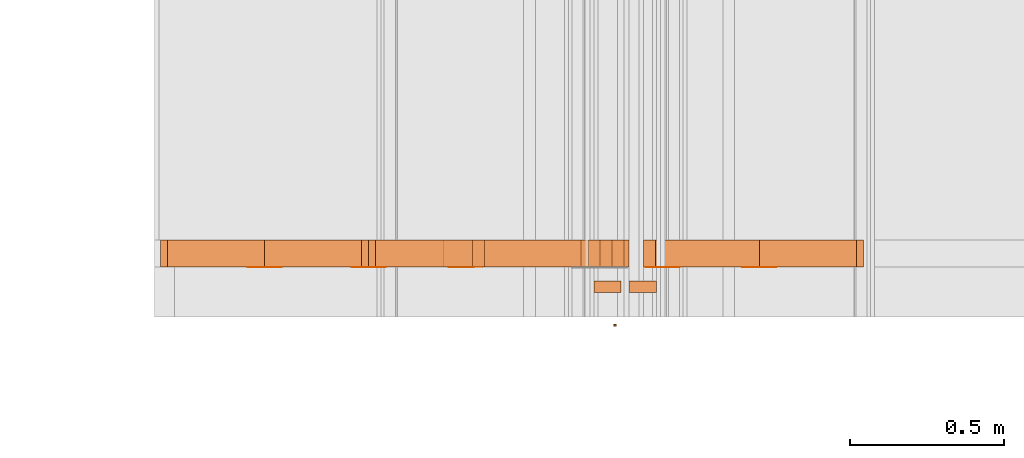
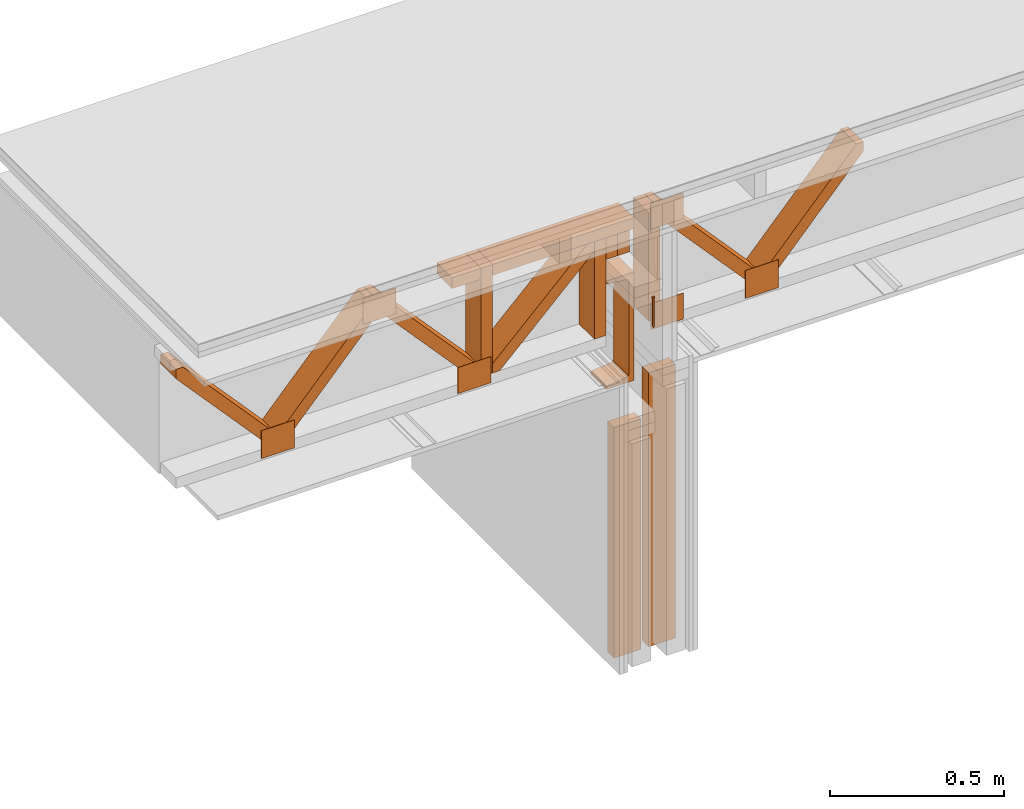
# One storey, part 13 of 22: 22 proxies.
"""IFC2X3 building model written with IfcOpenShell, lengths in feet."""

from ifc_helpers import new_model, entity, si_unit, converted_unit, frame, frame_2d, origin_with_axes, place, context, subcontext, project, spatial, polyline, rectangle, outline, extrude, source, transform, mapped, type_object, type_shapes, element, save


model = new_model("IFC2X3")

# Units and contexts
model_context = context("Model", 3, precision=1e-05)
plan_context = context("Plan", 2, precision=1e-05, world=frame_2d((0.0, 0.0, 0.0), x_axis=(1.0, 0.0, 0.0)))
body_context_1 = subcontext(model_context, "Body", "Model", "MODEL_VIEW")
body_context_2 = subcontext(model_context, "Body", "Model", "MODEL_VIEW")
ifc_project = project(units=[converted_unit("VOLUMEUNIT", "cubic foot", entity("IfcReal", 0.0283168467116885), si_unit("VOLUMEUNIT", "CUBIC_METRE"), dimensions=[3, 0, 0, 0, 0, 0, 0]), converted_unit("AREAUNIT", "square foot", entity("IfcReal", 0.09290304), si_unit("AREAUNIT", "SQUARE_METRE"), dimensions=[2, 0, 0, 0, 0, 0, 0]), converted_unit("LENGTHUNIT", "foot", entity("IfcReal", 0.3048), si_unit("LENGTHUNIT", "METRE"), dimensions=[1, 0, 0, 0, 0, 0, 0])], contexts=[model_context, plan_context])

# Site, building, storey
site_placement = place(None, origin_with_axes())
site = spatial("IfcSite", under=ifc_project, at=site_placement, CompositionType="ELEMENT")
building_placement = place(site_placement, origin_with_axes())
building = spatial("IfcBuilding", under=site, at=building_placement, Name="Building", CompositionType="ELEMENT")
storey_placement = place(building_placement, origin_with_axes())
storey = spatial("IfcBuildingStorey", under=building, at=storey_placement, Name="Storey", CompositionType="ELEMENT")

# Proxies
building_element_proxy_type = type_object("IfcBuildingElementProxyType", Name="FASTENERS INTO C CHANNEL TBD", PredefinedType="NOTDEFINED")
shared_shape = source(origin_with_axes(), body_context_2, "Body", "SweptSolid", [
    extrude(outline(polyline([(-0.222222268424948, -0.00687499849609737), (0.111111109768312, -0.00687499849609737), (0.111111109768312, -0.013750000047715), (0.117986103681129, -0.013750000047715), (0.117986103681129, 0.0137500031032353), (0.111111109768312, 0.0137500015754751), (0.111111109768312, 0.00687499925997744), (-0.222222243980786, 0.00687499925997744), (-0.23597223180642, -3.87233552310243e-09), (-0.222222268424948, -0.00687499849609737)])), frame((0.111111109768312, 1.11521265392398e-09, -0.020000005624895), z_axis=(-7.04017537600521e-08, -6.90586436234882e-14, -1.0), x_axis=(-1.0, -6.87492018869307e-09, 6.87492018869307e-08)), (-2.16271296119182e-14, 3.81939351257188e-08, -0.999999940395355), 0.0199999997321789),
])
type_shapes(building_element_proxy_type, [shared_shape])
proxy_1_placement = place(storey_placement, frame((1656.07292195318, 1.79566247413165, -60.7580212470428), z_axis=(-4.37113882867379e-08, -1.0, -3.30011807777566e-15), x_axis=(7.54979012640433e-08, 0.0, -1.0)))
element("IfcBuildingElementProxy", 1, at=proxy_1_placement, inside=storey, type_object=building_element_proxy_type, context=body_context_2, shape_type="MappedRepresentation", body=[
    mapped(shared_shape, transform((0.0, 0.0, 0.0), x_axis=(1.0, 0.0, 0.0), y_axis=(0.0, 1.0, 0.0), z_axis=(0.0, 0.0, 1.0), scale=1.0)),
])
proxy_2_placement = place(storey_placement, frame((1652.03174581052, 2.42488121423196, -61.9758708583401), z_axis=(0.0, 0.0, 1.0), x_axis=(1.0, 0.0, 0.0)))
element("IfcBuildingElementProxy", 2, at=proxy_2_placement, inside=storey, Name="Generic Models 855:Generic Models 1", context=body_context_1, shape_type="SweptSolid", body=[
    extrude(outline(polyline([(-0.784177421115515, -0.0648421487157426), (0.754565518750293, -0.0648422464923909), (0.835367211988905, 0.00826408231039373), (0.784177372227191, 0.0648422220482288), (-0.754565469861969, 0.0648421487157426), (-0.835367211988905, -0.00826398453374547), (-0.784177421115515, -0.0648421487157426)])), frame((0.859770405636685, 2.21605038198473e-07, 1.08333436522897), z_axis=(-5.63129143316132e-09, -1.0, -3.61698013762179e-08), x_axis=(-0.670913577079773, 3.05994660720899e-08, -0.741535544395447)), (3.05994909410856e-08, 2.00910239556151e-08, -1.0), 0.291666664589754),
])
for number, where, z_axis, x_axis, name in (
    (3, (1652.03174581052, 2.42488121423196, -61.9758708583401), (0.0, 0.0, 1.0), (1.0, 0.0, 0.0), "Generic Models 855:Generic Models 1"),
    (4, (1649.81441547864, 2.42488121423196, -61.9758708583401), (0.0, 0.0, 1.0), (1.0, 0.0, 0.0), "Generic Models 855:Generic Models 1"),
):
    element("IfcBuildingElementProxy", number, at=place(storey_placement, frame(where, z_axis=z_axis, x_axis=x_axis)), inside=storey, Name=name, context=body_context_1, shape_type="SweptSolid", body=[
        extrude(outline(polyline([(-0.784177225562218, -0.0648422709365529), (0.75456571430359, -0.0648423442690391), (0.835367309765553, 0.00826388675709722), (0.784177470003839, 0.0648420509390944), (-0.754565274308673, 0.0648421731599047), (-0.835367016435608, -0.00826420453120404), (-0.784177225562218, -0.0648422709365529)])), frame((1.96849052205173, 0.291666910638959, 1.08333377856908), z_axis=(0.0, 1.0, 0.0), x_axis=(-0.670913577079773, 0.0, 0.741535604000092)), (0.0, 1.67617116630936e-07, -1.0), 0.291666664589758),
    ])
proxy_3_placement = place(storey_placement, frame((1650.92308064458, 2.42488121423196, -61.8508731912127), z_axis=(0.0, 0.0, 1.0), x_axis=(1.0, 0.0, 0.0)))
element("IfcBuildingElementProxy", 5, at=proxy_3_placement, inside=storey, Name="Generic Models 855:Generic Models 1", context=body_context_1, shape_type="SweptSolid", body=[
    extrude(rectangle(XDim=0.124999233345449, YDim=0.291669311091376, at=frame_2d((0.0, 0.0, 0.0))), frame((3.69392433191535, 0.145834848636717, 0.333333109307477), z_axis=(-1.56443593368749e-06, 0.0, -1.0), x_axis=(0.999999940395355, 0.0, -1.56443593368749e-06)), (-7.30079079858115e-07, 0.0, -1.0), 1.25000238621637),
])
proxy_4_placement = place(storey_placement, frame((1652.0804057284, 2.42211120178693, -61.6217035008228), z_axis=(0.0, 0.0, 1.0), x_axis=(1.0, 0.0, 0.0)))
element("IfcBuildingElementProxy", 6, at=proxy_4_placement, inside=storey, Name="Generic Models 852:Generic Models 1", context=body_context_1, shape_type="SweptSolid", body=[
    extrude(rectangle(XDim=0.360929982303518, YDim=0.00277022707595213, at=frame_2d((0.0, 0.0, 0.0))), frame((2.39778886942726, 0.00138511354766121, 0.0), z_axis=(0.0, 0.0, -1.0), x_axis=(-1.0, 0.0, 0.0)), (0.0, 0.0, -1.0), 0.301264184929359),
])
proxy_5_placement = place(storey_placement, frame((1652.156799797, 2.42211120178693, -61.6217035008228), z_axis=(0.0, 0.0, 1.0), x_axis=(1.0, 0.0, 0.0)))
element("IfcBuildingElementProxy", 7, at=proxy_5_placement, inside=storey, Name="Generic Models 852:Generic Models 1", context=body_context_1, shape_type="SweptSolid", body=[
    extrude(rectangle(XDim=0.360930148950862, YDim=0.00277022707595213, at=frame_2d((0.0, 0.0, 0.0))), frame((0.180465076363149, 0.00138511354766121, 0.0), z_axis=(0.0, 0.0, -1.0), x_axis=(1.0, 0.0, 0.0)), (0.0, 0.0, -1.0), 0.322097519461289),
])
proxy_6_placement = place(storey_placement, frame((1652.156799797, 2.42211120178693, -61.9550389567698), z_axis=(0.0, 0.0, 1.0), x_axis=(1.0, 0.0, 0.0)))
element("IfcBuildingElementProxy", 8, at=proxy_6_placement, inside=storey, Name="Generic Models 852:Generic Models 1", context=body_context_1, shape_type="SweptSolid", body=[
    extrude(rectangle(XDim=0.360930176725411, YDim=0.00277022707595213, at=frame_2d((0.0, 0.0, 0.0))), frame((1.28912702789457, 0.00138511354766121, 1.4904025071875), z_axis=(0.0, 0.0, -1.0), x_axis=(-1.0, 0.0, 0.0)), (0.0, 0.0, -1.0), 0.301264218204712),
])
proxy_7_placement = place(storey_placement, frame((1654.37403000559, 2.42488121423196, -61.9758708583401), z_axis=(0.0, 0.0, 1.0), x_axis=(1.0, 0.0, 0.0)))
element("IfcBuildingElementProxy", 9, at=proxy_7_placement, inside=storey, Name="Generic Models 855:Generic Models 1", context=body_context_1, shape_type="SweptSolid", body=[
    extrude(outline(polyline([(-0.735265679481461, -0.0655906534022859), (0.713212303132836, -0.0655906289581239), (0.789645677945745, 0.0120712116634439), (0.735265826146434, 0.0655907267347721), (-0.713212205356187, 0.0655908000672583), (-0.789645482392449, -0.0120712849959301), (-0.735265679481461, -0.0655906534022859)])), frame((0.859770405636685, 2.21605038198473e-07, 1.02083240281253), z_axis=(-8.11541855938458e-09, -1.0, -3.79092135460724e-08), x_axis=(0.712722897529602, -3.25061648709379e-08, 0.701445698738098)), (1.35110923338289e-07, -2.13262563164562e-08, -1.0), 0.291666664589757),
])
proxy_8_placement = place(storey_placement, frame((1652.15669967371, 2.42488121423196, -61.8508731912127), z_axis=(0.0, 0.0, 1.0), x_axis=(1.0, 0.0, 0.0)))
element("IfcBuildingElementProxy", 10, at=proxy_8_placement, inside=storey, Name="Generic Models 855:Generic Models 1", context=body_context_1, shape_type="SweptSolid", body=[
    extrude(rectangle(XDim=0.124999233345449, YDim=0.291669311091376, at=frame_2d((0.0, 0.0, 0.0))), frame((3.69392433191535, 0.145834848636717, 0.333333109307477), z_axis=(-1.56443593368749e-06, 0.0, -1.0), x_axis=(-0.999999940395355, 0.0, 1.56443593368749e-06)), (6.37369737432891e-07, 0.0, -0.999999940395355), 1.12499844996168),
])
proxy_9_placement = place(storey_placement, frame((1652.41361603023, 2.42488121423196, -61.8508731912127), z_axis=(0.0, 0.0, 1.0), x_axis=(1.0, 0.0, 0.0)))
element("IfcBuildingElementProxy", 11, at=proxy_9_placement, inside=storey, Name="Generic Models 855:Generic Models 1", context=body_context_1, shape_type="SweptSolid", body=[
    extrude(rectangle(XDim=0.128503544713239, YDim=0.291669311091376, at=frame_2d((0.0, 0.0, 0.0))), frame((3.69217217437864, 0.145834848636717, 1.20834181002119), z_axis=(-1.5217735835904e-06, 0.0, -1.0), x_axis=(-1.0, 0.0, 1.5217735835904e-06)), (-3.63855770046939e-06, 0.0, -1.0), 0.249989805171813),
])
proxy_10_placement = place(storey_placement, frame((1655.41871639061, 2.71654660933287, -62.1008497523511), z_axis=(3.21939587593079e-05, 9.57722249950166e-07, 0.999999940395355), x_axis=(-0.999999940395355, -3.89414338997085e-07, 3.21939587593079e-05)))
element("IfcBuildingElementProxy", 12, at=proxy_10_placement, inside=storey, Name="Generic Models 855:Generic Models 1", context=body_context_1, shape_type="SweptSolid", body=[
    extrude(rectangle(XDim=1.98303713705672, YDim=0.291666664589754, at=frame_2d((0.0, 0.0, 0.0))), frame((0.188303732476992, 0.145833528651966, 1.70833482517032), z_axis=(0.0, 0.0, -1.0), x_axis=(1.0, 0.0, 0.0)), (0.0, 0.0, -1.0), 0.125000015272121),
])
proxy_11_placement = place(storey_placement, frame((1656.06761541892, 2.65876393462103, -61.5175377352657), z_axis=(-3.89414367418794e-07, 1.0, -1.62920684942947e-07), x_axis=(-1.0, -3.89414367418794e-07, -1.00485898695359e-14)))
element("IfcBuildingElementProxy", 13, at=proxy_11_placement, inside=storey, Name="C Channel Beam", context=body_context_1, shape_type="SweptSolid", body=[
    extrude(outline(polyline([(0.599756484895241, -2.04648255180801e-08), (0.593993822577119, -0.00949974310537922), (0.536930148448218, -0.200430249057104), (0.529868474469723, -0.214637000495055), (0.516649511620754, -0.223409545820529), (0.500815267872623, -0.224397334409511), (-0.548653861903769, -0.0122080768184771), (-0.562860564453395, -0.00514639672894138), (-0.571633134223032, 0.00807256612002732), (-0.572620922812014, 0.0239068106320391), (-0.551027194486828, 0.222008895334296), (-0.552646571335204, 0.233001166128424), (-0.559345542837003, 0.242162813625624), (-0.569329320836881, 0.247039032850678), (-0.586977468075089, 0.250607269407883), (-0.648214200663129, -0.0522641056850357), (0.576993787851859, -0.299985552319079), (0.638230520439899, 0.00288583289525102), (0.620582373201691, 0.00645406926148559), (0.609488488025866, 0.00583948191680659), (0.599756484895241, -2.04648255180801e-08)])), frame((0.0251886731849646, 3.0555202579248e-09, -0.233880324861196), z_axis=(-2.21273438683056e-07, -5.26584535975871e-08, -1.0), x_axis=(0.198177069425583, 0.98016619682312, -4.07568165883276e-08)), (-3.36867685746256e-07, 2.34567281154341e-08, -1.0), 0.291667008292637),
])
proxy_12_placement = place(storey_placement, frame((1655.430330692, -0.783451576167204, -63.4761557491433), z_axis=(0.0, 0.0, 1.0), x_axis=(1.0, 0.0, 0.0)))
element("IfcBuildingElementProxy", 14, at=proxy_12_placement, inside=storey, Name="Plane", context=body_context_1, shape_type="SweptSolid", body=[
    extrude(rectangle(XDim=0.125000015272121, YDim=0.291666767700657, at=frame_2d((0.0, 0.0, 0.0))), frame((0.56250001306296, 2.99930689841744, -1.57206233717951), z_axis=(0.0, 0.0, -1.0), x_axis=(0.0, -1.0, 0.0)), (0.0, 0.0, -1.0), 2.65567319636568),
])
proxy_13_placement = place(storey_placement, frame((1655.80539252814, -0.783451576167204, -62.9761525652227), z_axis=(0.0, 0.0, 1.0), x_axis=(1.0, 0.0, 0.0)))
element("IfcBuildingElementProxy", 15, at=proxy_13_placement, inside=storey, Name="Plane", context=body_context_1, shape_type="SweptSolid", body=[
    extrude(rectangle(XDim=0.125000015272121, YDim=0.291666767700657, at=frame_2d((0.0, 0.0, 0.0))), frame((0.56250001306296, 2.99930689841744, -2.07206552110006), z_axis=(0.0, 0.0, -1.0), x_axis=(0.0, -1.0, 0.0)), (0.0, 0.0, -1.0), 3.1556764266711),
])
proxy_14_placement = place(storey_placement, frame((1656.50325184419, 2.42488140978525, -60.2675360331698), z_axis=(0.0, 0.0, 1.0), x_axis=(1.0, 0.0, 0.0)))
element("IfcBuildingElementProxy", 16, at=proxy_14_placement, inside=storey, Name="Generic Models 855:Generic Models 1", context=body_context_1, shape_type="SweptSolid", body=[
    extrude(outline(polyline([(0.516033616513405, -0.554331018542993), (0.624998944403305, -0.554331018542993), (0.624998846626657, -0.478032379951377), (-0.516033567625081, 0.554330920766345), (-0.624998895514981, 0.554330920766345), (-0.624998895514981, 0.478032331063053), (0.516033616513405, -0.554331018542993)])), frame((0.554370911415481, 0.291666690641501, -0.625000508829678), z_axis=(-2.56278482879679e-08, 1.0, 3.61701353313038e-08), x_axis=(0.0, 0.0, -1.0)), (0.0, -2.18547841160529e-15, -1.0), 0.291666664589754),
])
proxy_15_placement = place(storey_placement, frame((1658.72058217607, 2.42488140978525, -60.2675360331698), z_axis=(0.0, 0.0, 1.0), x_axis=(1.0, 0.0, 0.0)))
element("IfcBuildingElementProxy", 17, at=proxy_15_placement, inside=storey, Name="Generic Models 855:Generic Models 1", context=body_context_1, shape_type="SweptSolid", body=[
    extrude(outline(polyline([(-0.784177372227191, -0.0648421976040667), (0.754565518750293, -0.0648421548267831), (0.835367114212256, 0.00826409987963521), (0.784177323338866, 0.0648422587144719), (-0.754565420973645, 0.0648423442690391), (-0.835367114212256, -0.0082640334220696), (-0.784177372227191, -0.0648421976040667)])), frame((-0.554349009446272, 5.04959154105692e-08, -0.625001095489567), z_axis=(7.55355611392616e-10, -1.0, 1.2056714737696e-08), x_axis=(0.670913577079773, 9.44726075147173e-09, 0.741535604000092)), (-1.58169854103107e-07, 7.52889306454563e-09, -1.0), 0.291666664589758),
])
proxy_16_placement = place(storey_placement, frame((1656.378297981, 2.42488140978525, -60.2675360331698), z_axis=(0.0, 0.0, 1.0), x_axis=(1.0, 0.0, 0.0)))
element("IfcBuildingElementProxy", 18, at=proxy_16_placement, inside=storey, Name="Generic Models 855:Generic Models 1", context=body_context_1, shape_type="SweptSolid", body=[
    extrude(rectangle(XDim=0.291669311091376, YDim=0.124999233345449, at=frame_2d((0.0, 0.0, 0.0))), frame((0.0625012046474171, 0.145834653083421, -1.25000463539534), z_axis=(1.56443593368749e-06, 0.0, -1.0), x_axis=(0.0, 1.0, 0.0)), (0.0, 6.01322824422823e-07, -1.0), 1.25000289947842),
])
proxy_17_placement = place(storey_placement, frame((1654.18179329299, 2.42211120178693, -61.6217035008228), z_axis=(0.0, 0.0, 1.0), x_axis=(1.0, 0.0, 0.0)))
element("IfcBuildingElementProxy", 19, at=proxy_17_placement, inside=storey, Name="Generic Models 852:Generic Models 1", context=body_context_1, shape_type="SweptSolid", body=[
    extrude(rectangle(XDim=0.360929982303518, YDim=0.00277022707595213, at=frame_2d((0.0, 0.0, 0.0))), frame((2.39778886942726, 0.00138511354766121, 0.0), z_axis=(0.0, 0.0, -1.0), x_axis=(-1.0, 0.0, 0.0)), (0.0, 0.0, -1.0), 0.301264184929359),
])
proxy_18_placement = place(storey_placement, frame((1657.43139472221, 2.42211120178693, -61.6217035008228), z_axis=(0.0, 0.0, 1.0), x_axis=(1.0, 0.0, 0.0)))
element("IfcBuildingElementProxy", 20, at=proxy_18_placement, inside=storey, Name="Generic Models 852:Generic Models 1", context=body_context_1, shape_type="SweptSolid", body=[
    extrude(rectangle(XDim=0.360930148950862, YDim=0.00277022707595213, at=frame_2d((0.0, 0.0, 0.0))), frame((0.180465076363149, 0.00138511354766121, 0.0), z_axis=(0.0, 0.0, -1.0), x_axis=(1.0, 0.0, 0.0)), (0.0, 0.0, -1.0), 0.322097519461289),
])
proxy_19_placement = place(storey_placement, frame((1655.29045845893, 2.42211120178693, -61.9550389567698), z_axis=(0.0, 0.0, 1.0), x_axis=(1.0, 0.0, 0.0)))
element("IfcBuildingElementProxy", 21, at=proxy_19_placement, inside=storey, Name="Generic Models 852:Generic Models 1", context=body_context_1, shape_type="SweptSolid", body=[
    extrude(rectangle(XDim=0.360930176725411, YDim=0.00277022707595213, at=frame_2d((0.0, 0.0, 0.0))), frame((1.28912702789457, 0.00138511354766121, 1.4904025071875), z_axis=(0.0, 0.0, -1.0), x_axis=(-1.0, 0.0, 0.0)), (0.0, 0.0, -1.0), 0.301264218204712),
])
proxy_20_placement = place(storey_placement, frame((1652.26433220811, 2.42488121423196, -61.8508731912127), z_axis=(0.0, 0.0, 1.0), x_axis=(1.0, 0.0, 0.0)))
element("IfcBuildingElementProxy", 22, at=proxy_20_placement, inside=storey, Name="Generic Models 855:Generic Models 1", context=body_context_1, shape_type="SweptSolid", body=[
    extrude(rectangle(XDim=0.128503544713239, YDim=0.291669311091376, at=frame_2d((0.0, 0.0, 0.0))), frame((3.71299781824347, 0.145834848636717, 1.20834181002119), z_axis=(-1.5217735835904e-06, 0.0, -1.0), x_axis=(-1.0, 0.0, 1.5217735835904e-06)), (-3.63855860996409e-06, 0.0, -1.0), 0.249989734996232),
])

save(model, "model.ifc")
